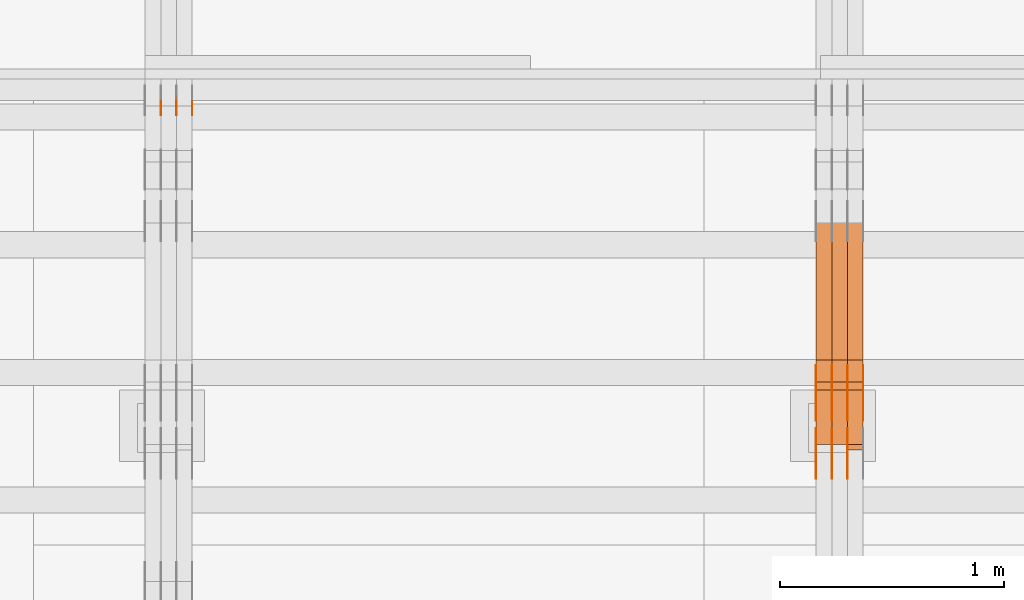
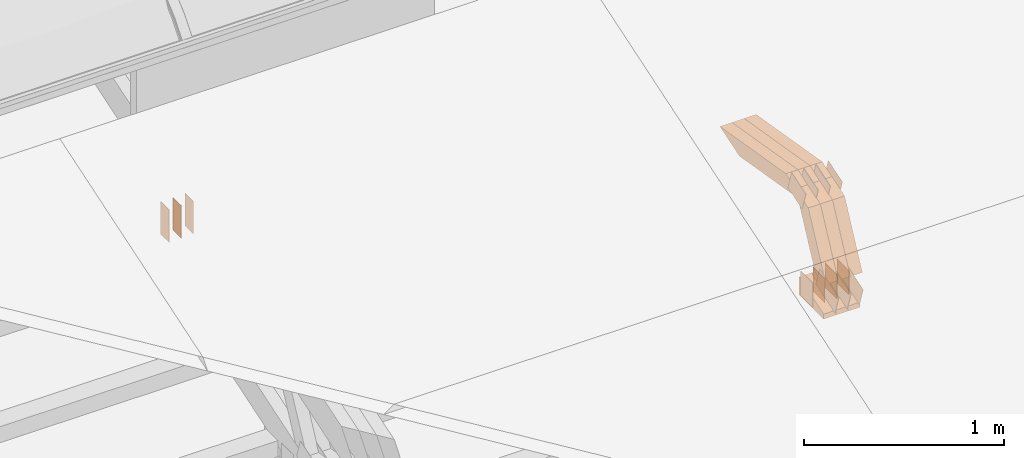
# One storey, part 282 of 385: 30 proxies.
"""IFC2X3 building model written with IfcOpenShell, lengths in millimetres."""

from ifc_helpers import new_model, entity, si_unit, converted_unit, derived_unit, direction, frame, frame_2d, origin, place, context, subcontext, project, spatial, polyline, rectangle, outline, extrude, source, transform, mapped, material, type_object, type_shapes, element, save


model = new_model("IFC2X3")

# Units and contexts
model_context = context("Model", 3, precision=0.01, world=origin(), true_north=direction((6.12303176911189e-17, 1.0)))
body_context = subcontext(model_context, "Body", "Model", "MODEL_VIEW")
ifc_project = project(units=[si_unit("LENGTHUNIT", "METRE", prefix="MILLI"), si_unit("AREAUNIT", "SQUARE_METRE"), si_unit("VOLUMEUNIT", "CUBIC_METRE"), converted_unit("PLANEANGLEUNIT", "DEGREE", entity("IfcRatioMeasure", 0.0174532925199433), si_unit("PLANEANGLEUNIT", "RADIAN"), dimensions=[0, 0, 0, 0, 0, 0, 0]), si_unit("MASSUNIT", "GRAM", prefix="KILO"), derived_unit("MASSDENSITYUNIT", [(si_unit("MASSUNIT", "GRAM", prefix="KILO"), 1), (si_unit("LENGTHUNIT", "METRE"), -3)]), si_unit("TIMEUNIT", "SECOND"), si_unit("FREQUENCYUNIT", "HERTZ"), si_unit("THERMODYNAMICTEMPERATUREUNIT", "DEGREE_CELSIUS"), derived_unit("THERMALTRANSMITTANCEUNIT", [(si_unit("MASSUNIT", "GRAM", prefix="KILO"), 1), (si_unit("THERMODYNAMICTEMPERATUREUNIT", "KELVIN"), -1), (si_unit("TIMEUNIT", "SECOND"), -3)]), derived_unit("VOLUMETRICFLOWRATEUNIT", [(si_unit("LENGTHUNIT", "METRE"), 3), (si_unit("TIMEUNIT", "SECOND"), -1)]), si_unit("ELECTRICCURRENTUNIT", "AMPERE"), si_unit("ELECTRICVOLTAGEUNIT", "VOLT"), si_unit("POWERUNIT", "WATT"), si_unit("FORCEUNIT", "NEWTON", prefix="KILO"), si_unit("ILLUMINANCEUNIT", "LUX"), si_unit("LUMINOUSFLUXUNIT", "LUMEN"), si_unit("LUMINOUSINTENSITYUNIT", "CANDELA"), derived_unit("USERDEFINED", [(si_unit("MASSUNIT", "GRAM", prefix="KILO"), -1), (si_unit("LENGTHUNIT", "METRE"), -2), (si_unit("TIMEUNIT", "SECOND"), 3), (si_unit("LUMINOUSFLUXUNIT", "LUMEN"), 1)]), derived_unit("LINEARVELOCITYUNIT", [(si_unit("LENGTHUNIT", "METRE"), 1), (si_unit("TIMEUNIT", "SECOND"), -1)]), si_unit("PRESSUREUNIT", "PASCAL"), derived_unit("USERDEFINED", [(si_unit("LENGTHUNIT", "METRE"), -2), (si_unit("MASSUNIT", "GRAM", prefix="KILO"), 1), (si_unit("TIMEUNIT", "SECOND"), -2)])], contexts=[model_context])

# Site, building, storey
site_placement = place(None, origin())
site = spatial("IfcSite", under=ifc_project, at=site_placement, CompositionType="ELEMENT")
building_placement = place(site_placement, origin())
building = spatial("IfcBuilding", under=site, at=building_placement, CompositionType="ELEMENT")
storey_placement = place(building_placement, origin())
storey = spatial("IfcBuildingStorey", under=building, at=storey_placement, Name="Default", CompositionType="ELEMENT", Elevation=0.0)

# Proxies
ifc_material_1 = material(Name="IfcSurfaceStyle #482430")
building_element_proxy_type_1 = type_object("IfcBuildingElementProxyType", PredefinedType="NOTDEFINED", material=ifc_material_1)
shared_shape_1 = source(origin(), body_context, "Body", "SweptSolid", [
    extrude(outline(polyline([(-99.9997874178038, -60.0000528641967), (99.9998102700997, -60.0000528641967), (99.9998251396068, 60.0000528641967), (-99.9998479919027, 60.0000528641967), (-99.9997874178038, -60.0000528641967)])), frame((99.9999918898597, 60.0000528641967, 0.0), z_axis=(0.0, 0.0, 1.0), x_axis=(-1.0, 0.0, 0.0)), (0.0, 0.0, 1.0), 1.3),
])
type_shapes(building_element_proxy_type_1, [shared_shape_1])
proxy_1_placement = place(building_placement, frame((39316.3, 11991.9568177725, 3072.52282247925), z_axis=(-1.0, 0.0, 0.0), x_axis=(0.0, 0.951056516295124, 0.309016994375039)))
element("IfcBuildingElementProxy", 1, at=proxy_1_placement, inside=storey, type_object=building_element_proxy_type_1, material=ifc_material_1, context=body_context, shape_type="MappedRepresentation", body=[
    mapped(shared_shape_1, transform((0.0, 0.0, 0.0), scale=1.0)),
])
ifc_material_2 = material(Name="IfcSurfaceStyle #482373")
building_element_proxy_type_2 = type_object("IfcBuildingElementProxyType", PredefinedType="NOTDEFINED", material=ifc_material_2)
shared_shape_2 = source(origin(), body_context, "Body", "SweptSolid", [
    extrude(outline(polyline([(-99.9997874178038, -60.0000528641967), (99.9998102700997, -60.0000528641967), (99.9998251396068, 60.0000528641967), (-99.9998479919027, 60.0000528641967), (-99.9997874178038, -60.0000528641967)])), frame((99.9999918898597, 60.0000528641967, 0.0), z_axis=(0.0, 0.0, 1.0), x_axis=(-1.0, 0.0, 0.0)), (0.0, 0.0, 1.0), 1.29999999999998),
])
type_shapes(building_element_proxy_type_2, [shared_shape_2])
proxy_2_placement = place(building_placement, frame((39245.0, 11991.9568177725, 3072.52282247925), z_axis=(-1.0, 0.0, 0.0), x_axis=(0.0, 0.951056516295124, 0.309016994375039)))
element("IfcBuildingElementProxy", 2, at=proxy_2_placement, inside=storey, type_object=building_element_proxy_type_2, material=ifc_material_2, context=body_context, shape_type="MappedRepresentation", body=[
    mapped(shared_shape_2, transform((0.0, 0.0, 0.0), scale=1.0)),
])
ifc_material_3 = material(Name="IfcSurfaceStyle #482316")
building_element_proxy_type_3 = type_object("IfcBuildingElementProxyType", PredefinedType="NOTDEFINED", material=ifc_material_3)
shared_shape_3 = source(origin(), body_context, "Body", "SweptSolid", [
    extrude(outline(polyline([(-99.9997874178038, -60.0000528641967), (99.9998102700997, -60.0000528641967), (99.9998251396068, 60.0000528641967), (-99.9998479919027, 60.0000528641967), (-99.9997874178038, -60.0000528641967)])), frame((99.9999918898597, 60.0000528641967, 0.0), z_axis=(0.0, 0.0, 1.0), x_axis=(-1.0, 0.0, 0.0)), (0.0, 0.0, 1.0), 1.29999999999998),
])
type_shapes(building_element_proxy_type_3, [shared_shape_3])
proxy_3_placement = place(building_placement, frame((39246.3, 11991.9568177725, 3072.52282247925), z_axis=(-1.0, 0.0, 0.0), x_axis=(0.0, 0.951056516295124, 0.309016994375039)))
element("IfcBuildingElementProxy", 3, at=proxy_3_placement, inside=storey, type_object=building_element_proxy_type_3, material=ifc_material_3, context=body_context, shape_type="MappedRepresentation", body=[
    mapped(shared_shape_3, transform((0.0, 0.0, 0.0), scale=1.0)),
])
ifc_material_4 = material(Name="IfcSurfaceStyle #482259")
building_element_proxy_type_4 = type_object("IfcBuildingElementProxyType", PredefinedType="NOTDEFINED", material=ifc_material_4)
shared_shape_4 = source(origin(), body_context, "Body", "SweptSolid", [
    extrude(outline(polyline([(-99.9997874178038, -60.0000528641967), (99.9998102700997, -60.0000528641967), (99.9998251396068, 60.0000528641967), (-99.9998479919027, 60.0000528641967), (-99.9997874178038, -60.0000528641967)])), frame((99.9999918898597, 60.0000528641967, 0.0), z_axis=(0.0, 0.0, 1.0), x_axis=(-1.0, 0.0, 0.0)), (0.0, 0.0, 1.0), 1.29999999999999),
])
type_shapes(building_element_proxy_type_4, [shared_shape_4])
proxy_4_placement = place(building_placement, frame((39175.0, 11991.9568177725, 3072.52282247925), z_axis=(-1.0, 0.0, 0.0), x_axis=(0.0, 0.951056516295124, 0.309016994375039)))
element("IfcBuildingElementProxy", 4, at=proxy_4_placement, inside=storey, type_object=building_element_proxy_type_4, material=ifc_material_4, context=body_context, shape_type="MappedRepresentation", body=[
    mapped(shared_shape_4, transform((0.0, 0.0, 0.0), scale=1.0)),
])
ifc_material_5 = material(Name="IfcSurfaceStyle #482202")
building_element_proxy_type_5 = type_object("IfcBuildingElementProxyType", PredefinedType="NOTDEFINED", material=ifc_material_5)
shared_shape_5 = source(origin(), body_context, "Body", "SweptSolid", [
    extrude(rectangle(XDim=150.0, YDim=119.999999999985, at=frame_2d((-7.105427357601e-15, 0.0), x_axis=(1.0, 0.0))), frame((75.0, 60.0, 0.0), z_axis=(0.0, 0.0, 1.0), x_axis=(-1.0, 0.0, 0.0)), (0.0, 0.0, 1.0), 1.3),
])
type_shapes(building_element_proxy_type_5, [shared_shape_5])
proxy_5_placement = place(building_placement, frame((39386.3, 12372.95703125, 3007.04687500001), z_axis=(-1.0, 0.0, 0.0), x_axis=(0.0, 0.0, -1.0)))
element("IfcBuildingElementProxy", 5, at=proxy_5_placement, inside=storey, type_object=building_element_proxy_type_5, material=ifc_material_5, context=body_context, shape_type="MappedRepresentation", body=[
    mapped(shared_shape_5, transform((0.0, 0.0, 0.0), scale=1.0)),
])
ifc_material_6 = material(Name="IfcSurfaceStyle #482145")
building_element_proxy_type_6 = type_object("IfcBuildingElementProxyType", PredefinedType="NOTDEFINED", material=ifc_material_6)
shared_shape_6 = source(origin(), body_context, "Body", "SweptSolid", [
    extrude(rectangle(XDim=150.0, YDim=119.999999999985, at=frame_2d((-7.105427357601e-15, 0.0), x_axis=(1.0, 0.0))), frame((75.0, 60.0, 0.0), z_axis=(0.0, 0.0, 1.0), x_axis=(-1.0, 0.0, 0.0)), (0.0, 0.0, 1.0), 1.3),
])
type_shapes(building_element_proxy_type_6, [shared_shape_6])
proxy_6_placement = place(building_placement, frame((39315.0, 12372.95703125, 3007.04687500001), z_axis=(-1.0, 0.0, 0.0), x_axis=(0.0, 0.0, -1.0)))
element("IfcBuildingElementProxy", 6, at=proxy_6_placement, inside=storey, type_object=building_element_proxy_type_6, material=ifc_material_6, context=body_context, shape_type="MappedRepresentation", body=[
    mapped(shared_shape_6, transform((0.0, 0.0, 0.0), scale=1.0)),
])
ifc_material_7 = material(Name="IfcSurfaceStyle #482088")
building_element_proxy_type_7 = type_object("IfcBuildingElementProxyType", PredefinedType="NOTDEFINED", material=ifc_material_7)
shared_shape_7 = source(origin(), body_context, "Body", "SweptSolid", [
    extrude(rectangle(XDim=150.0, YDim=119.999999999985, at=frame_2d((-7.105427357601e-15, 0.0), x_axis=(1.0, 0.0))), frame((75.0, 60.0, 0.0), z_axis=(0.0, 0.0, 1.0), x_axis=(-1.0, 0.0, 0.0)), (0.0, 0.0, 1.0), 1.3),
])
type_shapes(building_element_proxy_type_7, [shared_shape_7])
proxy_7_placement = place(building_placement, frame((39316.3, 12372.95703125, 3007.04687500001), z_axis=(-1.0, 0.0, 0.0), x_axis=(0.0, 0.0, -1.0)))
element("IfcBuildingElementProxy", 7, at=proxy_7_placement, inside=storey, type_object=building_element_proxy_type_7, material=ifc_material_7, context=body_context, shape_type="MappedRepresentation", body=[
    mapped(shared_shape_7, transform((0.0, 0.0, 0.0), scale=1.0)),
])
ifc_material_8 = material(Name="IfcSurfaceStyle #482031")
building_element_proxy_type_8 = type_object("IfcBuildingElementProxyType", PredefinedType="NOTDEFINED", material=ifc_material_8)
shared_shape_8 = source(origin(), body_context, "Body", "SweptSolid", [
    extrude(rectangle(XDim=150.0, YDim=119.999999999985, at=frame_2d((-7.105427357601e-15, 0.0), x_axis=(1.0, 0.0))), frame((75.0, 60.0, 0.0), z_axis=(0.0, 0.0, 1.0), x_axis=(-1.0, 0.0, 0.0)), (0.0, 0.0, 1.0), 1.29999999999999),
])
type_shapes(building_element_proxy_type_8, [shared_shape_8])
proxy_8_placement = place(building_placement, frame((39245.0, 12372.95703125, 3007.04687500001), z_axis=(-1.0, 0.0, 0.0), x_axis=(0.0, 0.0, -1.0)))
element("IfcBuildingElementProxy", 8, at=proxy_8_placement, inside=storey, type_object=building_element_proxy_type_8, material=ifc_material_8, context=body_context, shape_type="MappedRepresentation", body=[
    mapped(shared_shape_8, transform((0.0, 0.0, 0.0), scale=1.0)),
])
ifc_material_9 = material(Name="IfcSurfaceStyle #481974")
building_element_proxy_type_9 = type_object("IfcBuildingElementProxyType", PredefinedType="NOTDEFINED", material=ifc_material_9)
shared_shape_9 = source(origin(), body_context, "Body", "SweptSolid", [
    extrude(rectangle(XDim=150.0, YDim=119.999999999985, at=frame_2d((-7.105427357601e-15, 0.0), x_axis=(1.0, 0.0))), frame((75.0, 60.0, 0.0), z_axis=(0.0, 0.0, 1.0), x_axis=(-1.0, 0.0, 0.0)), (0.0, 0.0, 1.0), 1.29999999999999),
])
type_shapes(building_element_proxy_type_9, [shared_shape_9])
proxy_9_placement = place(building_placement, frame((39246.3, 12372.95703125, 3007.04687500001), z_axis=(-1.0, 0.0, 0.0), x_axis=(0.0, 0.0, -1.0)))
element("IfcBuildingElementProxy", 9, at=proxy_9_placement, inside=storey, type_object=building_element_proxy_type_9, material=ifc_material_9, context=body_context, shape_type="MappedRepresentation", body=[
    mapped(shared_shape_9, transform((0.0, 0.0, 0.0), scale=1.0)),
])
ifc_material_10 = material(Name="IfcSurfaceStyle #481917")
building_element_proxy_type_10 = type_object("IfcBuildingElementProxyType", PredefinedType="NOTDEFINED", material=ifc_material_10)
shared_shape_10 = source(origin(), body_context, "Body", "SweptSolid", [
    extrude(rectangle(XDim=150.0, YDim=119.999999999985, at=frame_2d((-7.105427357601e-15, 0.0), x_axis=(1.0, 0.0))), frame((75.0, 60.0, 0.0), z_axis=(0.0, 0.0, 1.0), x_axis=(-1.0, 0.0, 0.0)), (0.0, 0.0, 1.0), 1.29999999999999),
])
type_shapes(building_element_proxy_type_10, [shared_shape_10])
proxy_10_placement = place(building_placement, frame((39175.0, 12372.95703125, 3007.04687500001), z_axis=(-1.0, 0.0, 0.0), x_axis=(0.0, 0.0, -1.0)))
element("IfcBuildingElementProxy", 10, at=proxy_10_placement, inside=storey, type_object=building_element_proxy_type_10, material=ifc_material_10, context=body_context, shape_type="MappedRepresentation", body=[
    mapped(shared_shape_10, transform((0.0, 0.0, 0.0), scale=1.0)),
])
ifc_material_11 = material(Name="IfcSurfaceStyle #475020")
building_element_proxy_type_11 = type_object("IfcBuildingElementProxyType", PredefinedType="NOTDEFINED", material=ifc_material_11)
shared_shape_11 = source(origin(), body_context, "Body", "SweptSolid", [
    extrude(outline(polyline([(-74.9998754286244, -60.0000016373506), (74.9998605591063, -60.0000016373506), (74.9998754286244, 60.0000016373506), (-74.9998605591063, 60.0000016373506), (-74.9998754286244, -60.0000016373506)])), frame((74.9998754286244, 60.0000016373506, 0.0), z_axis=(0.0, 0.0, 1.0), x_axis=(-1.0, 0.0, 0.0)), (0.0, 0.0, 1.0), 1.3),
])
type_shapes(building_element_proxy_type_11, [shared_shape_11])
proxy_11_placement = place(building_placement, frame((39386.3, 12321.1620861463, 3506.17707344366), z_axis=(-1.0, 0.0, 0.0), x_axis=(0.0, 0.951056516295154, 0.309016994374948)))
element("IfcBuildingElementProxy", 11, at=proxy_11_placement, inside=storey, type_object=building_element_proxy_type_11, material=ifc_material_11, context=body_context, shape_type="MappedRepresentation", body=[
    mapped(shared_shape_11, transform((0.0, 0.0, 0.0), scale=1.0)),
])
ifc_material_12 = material(Name="IfcSurfaceStyle #474963")
building_element_proxy_type_12 = type_object("IfcBuildingElementProxyType", PredefinedType="NOTDEFINED", material=ifc_material_12)
shared_shape_12 = source(origin(), body_context, "Body", "SweptSolid", [
    extrude(outline(polyline([(-74.9998754286244, -60.0000016373506), (74.9998605591063, -60.0000016373506), (74.9998754286244, 60.0000016373506), (-74.9998605591063, 60.0000016373506), (-74.9998754286244, -60.0000016373506)])), frame((74.9998754286244, 60.0000016373506, 0.0), z_axis=(0.0, 0.0, 1.0), x_axis=(-1.0, 0.0, 0.0)), (0.0, 0.0, 1.0), 1.3),
])
type_shapes(building_element_proxy_type_12, [shared_shape_12])
proxy_12_placement = place(building_placement, frame((39315.0, 12321.1620861463, 3506.17707344366), z_axis=(-1.0, 0.0, 0.0), x_axis=(0.0, 0.951056516295154, 0.309016994374948)))
element("IfcBuildingElementProxy", 12, at=proxy_12_placement, inside=storey, type_object=building_element_proxy_type_12, material=ifc_material_12, context=body_context, shape_type="MappedRepresentation", body=[
    mapped(shared_shape_12, transform((0.0, 0.0, 0.0), scale=1.0)),
])
ifc_material_13 = material(Name="IfcSurfaceStyle #474906")
building_element_proxy_type_13 = type_object("IfcBuildingElementProxyType", PredefinedType="NOTDEFINED", material=ifc_material_13)
shared_shape_13 = source(origin(), body_context, "Body", "SweptSolid", [
    extrude(outline(polyline([(-74.9998754286244, -60.0000016373506), (74.9998605591063, -60.0000016373506), (74.9998754286244, 60.0000016373506), (-74.9998605591063, 60.0000016373506), (-74.9998754286244, -60.0000016373506)])), frame((74.9998754286244, 60.0000016373506, 0.0), z_axis=(0.0, 0.0, 1.0), x_axis=(-1.0, 0.0, 0.0)), (0.0, 0.0, 1.0), 1.3),
])
type_shapes(building_element_proxy_type_13, [shared_shape_13])
proxy_13_placement = place(building_placement, frame((39316.3, 12321.1620861463, 3506.17707344366), z_axis=(-1.0, 0.0, 0.0), x_axis=(0.0, 0.951056516295154, 0.309016994374948)))
element("IfcBuildingElementProxy", 13, at=proxy_13_placement, inside=storey, type_object=building_element_proxy_type_13, material=ifc_material_13, context=body_context, shape_type="MappedRepresentation", body=[
    mapped(shared_shape_13, transform((0.0, 0.0, 0.0), scale=1.0)),
])
ifc_material_14 = material(Name="IfcSurfaceStyle #474849")
building_element_proxy_type_14 = type_object("IfcBuildingElementProxyType", PredefinedType="NOTDEFINED", material=ifc_material_14)
shared_shape_14 = source(origin(), body_context, "Body", "SweptSolid", [
    extrude(outline(polyline([(-74.9998754286244, -60.0000016373506), (74.9998605591063, -60.0000016373506), (74.9998754286244, 60.0000016373506), (-74.9998605591063, 60.0000016373506), (-74.9998754286244, -60.0000016373506)])), frame((74.9998754286244, 60.0000016373506, 0.0), z_axis=(0.0, 0.0, 1.0), x_axis=(-1.0, 0.0, 0.0)), (0.0, 0.0, 1.0), 1.29999999999999),
])
type_shapes(building_element_proxy_type_14, [shared_shape_14])
proxy_14_placement = place(building_placement, frame((39245.0, 12321.1620861463, 3506.17707344366), z_axis=(-1.0, 0.0, 0.0), x_axis=(0.0, 0.951056516295154, 0.309016994374948)))
element("IfcBuildingElementProxy", 14, at=proxy_14_placement, inside=storey, type_object=building_element_proxy_type_14, material=ifc_material_14, context=body_context, shape_type="MappedRepresentation", body=[
    mapped(shared_shape_14, transform((0.0, 0.0, 0.0), scale=1.0)),
])
ifc_material_15 = material(Name="IfcSurfaceStyle #474792")
building_element_proxy_type_15 = type_object("IfcBuildingElementProxyType", PredefinedType="NOTDEFINED", material=ifc_material_15)
shared_shape_15 = source(origin(), body_context, "Body", "SweptSolid", [
    extrude(outline(polyline([(-74.9998754286244, -60.0000016373506), (74.9998605591063, -60.0000016373506), (74.9998754286244, 60.0000016373506), (-74.9998605591063, 60.0000016373506), (-74.9998754286244, -60.0000016373506)])), frame((74.9998754286244, 60.0000016373506, 0.0), z_axis=(0.0, 0.0, 1.0), x_axis=(-1.0, 0.0, 0.0)), (0.0, 0.0, 1.0), 1.29999999999999),
])
type_shapes(building_element_proxy_type_15, [shared_shape_15])
proxy_15_placement = place(building_placement, frame((39246.3, 12321.1620861463, 3506.17707344366), z_axis=(-1.0, 0.0, 0.0), x_axis=(0.0, 0.951056516295154, 0.309016994374948)))
element("IfcBuildingElementProxy", 15, at=proxy_15_placement, inside=storey, type_object=building_element_proxy_type_15, material=ifc_material_15, context=body_context, shape_type="MappedRepresentation", body=[
    mapped(shared_shape_15, transform((0.0, 0.0, 0.0), scale=1.0)),
])
ifc_material_16 = material(Name="IfcSurfaceStyle #474735")
building_element_proxy_type_16 = type_object("IfcBuildingElementProxyType", PredefinedType="NOTDEFINED", material=ifc_material_16)
shared_shape_16 = source(origin(), body_context, "Body", "SweptSolid", [
    extrude(outline(polyline([(-74.9998754286244, -60.0000016373506), (74.9998605591063, -60.0000016373506), (74.9998754286244, 60.0000016373506), (-74.9998605591063, 60.0000016373506), (-74.9998754286244, -60.0000016373506)])), frame((74.9998754286244, 60.0000016373506, 0.0), z_axis=(0.0, 0.0, 1.0), x_axis=(-1.0, 0.0, 0.0)), (0.0, 0.0, 1.0), 1.29999999999999),
])
type_shapes(building_element_proxy_type_16, [shared_shape_16])
proxy_16_placement = place(building_placement, frame((39175.0, 12321.1620861463, 3506.17707344366), z_axis=(-1.0, 0.0, 0.0), x_axis=(0.0, 0.951056516295154, 0.309016994374948)))
element("IfcBuildingElementProxy", 16, at=proxy_16_placement, inside=storey, type_object=building_element_proxy_type_16, material=ifc_material_16, context=body_context, shape_type="MappedRepresentation", body=[
    mapped(shared_shape_16, transform((0.0, 0.0, 0.0), scale=1.0)),
])
ifc_material_17 = material(Name="IfcSurfaceStyle #466560")
building_element_proxy_type_17 = type_object("IfcBuildingElementProxyType", Name="T1-E1 466558", PredefinedType="NOTDEFINED", material=ifc_material_17)
shared_shape_17 = source(origin(), body_context, "Body", "SweptSolid", [
    extrude(outline(polyline([(-75.1378173828004, -122.500000000005), (35.3350830078246, -122.500000000005), (35.3350830078004, 122.500000000005), (4.46765136717545, 122.500000000005), (-75.1378173828004, -122.500000000005)])), frame((35.3350830078246, 122.500000104877, 0.0), z_axis=(0.0, 0.0, 1.0), x_axis=(-1.0, 0.0, 0.0)), (0.0, 0.0, 1.0), 70.0),
])
type_shapes(building_element_proxy_type_17, [shared_shape_17])
proxy_17_placement = place(building_placement, frame((39385.0, 12145.0, 2849.54565429685), z_axis=(-1.0, 0.0, 0.0), x_axis=(0.0, 0.0, 1.0)))
element("IfcBuildingElementProxy", 17, at=proxy_17_placement, inside=storey, type_object=building_element_proxy_type_17, material=ifc_material_17, Name="T1-E1", context=body_context, shape_type="MappedRepresentation", body=[
    mapped(shared_shape_17, transform((0.0, 0.0, 0.0), scale=1.0)),
])
ifc_material_18 = material(Name="IfcSurfaceStyle #466503")
building_element_proxy_type_18 = type_object("IfcBuildingElementProxyType", Name="T1-E1 466501", PredefinedType="NOTDEFINED", material=ifc_material_18)
shared_shape_18 = source(origin(), body_context, "Body", "SweptSolid", [
    extrude(outline(polyline([(-75.1378173828004, -122.500000000005), (35.3350830078246, -122.500000000005), (35.3350830078004, 122.500000000005), (4.46765136717545, 122.500000000005), (-75.1378173828004, -122.500000000005)])), frame((35.3350830078246, 122.500000104877, 0.0), z_axis=(0.0, 0.0, 1.0), x_axis=(-1.0, 0.0, 0.0)), (0.0, 0.0, 1.0), 70.0),
])
type_shapes(building_element_proxy_type_18, [shared_shape_18])
proxy_18_placement = place(building_placement, frame((39315.0, 12145.0, 2849.54565429685), z_axis=(-1.0, 0.0, 0.0), x_axis=(0.0, 0.0, 1.0)))
element("IfcBuildingElementProxy", 18, at=proxy_18_placement, inside=storey, type_object=building_element_proxy_type_18, material=ifc_material_18, Name="T1-E1", context=body_context, shape_type="MappedRepresentation", body=[
    mapped(shared_shape_18, transform((0.0, 0.0, 0.0), scale=1.0)),
])
ifc_material_19 = material(Name="IfcSurfaceStyle #466446")
building_element_proxy_type_19 = type_object("IfcBuildingElementProxyType", Name="T1-E1 466444", PredefinedType="NOTDEFINED", material=ifc_material_19)
shared_shape_19 = source(origin(), body_context, "Body", "SweptSolid", [
    extrude(outline(polyline([(-75.1378173828004, -122.500000000005), (35.3350830078246, -122.500000000005), (35.3350830078004, 122.500000000005), (4.46765136717545, 122.500000000005), (-75.1378173828004, -122.500000000005)])), frame((35.3350830078246, 122.500000104877, 0.0), z_axis=(0.0, 0.0, 1.0), x_axis=(-1.0, 0.0, 0.0)), (0.0, 0.0, 1.0), 70.0),
])
type_shapes(building_element_proxy_type_19, [shared_shape_19])
proxy_19_placement = place(building_placement, frame((39245.0, 12145.0, 2849.54565429685), z_axis=(-1.0, 0.0, 0.0), x_axis=(0.0, 0.0, 1.0)))
element("IfcBuildingElementProxy", 19, at=proxy_19_placement, inside=storey, type_object=building_element_proxy_type_19, material=ifc_material_19, Name="T1-E1", context=body_context, shape_type="MappedRepresentation", body=[
    mapped(shared_shape_19, transform((0.0, 0.0, 0.0), scale=1.0)),
])
ifc_material_20 = material(Name="IfcSurfaceStyle #464832")
building_element_proxy_type_20 = type_object("IfcBuildingElementProxyType", Name="T1-W7 464830", PredefinedType="NOTDEFINED", material=ifc_material_20)
shared_shape_20 = source(origin(), body_context, "Body", "SweptSolid", [
    extrude(outline(polyline([(-296.174043820986, -47.5000676566704), (297.841254477443, -47.5000676566704), (283.518570346415, -7.10254316533821e-06), (192.674144473719, 47.500071207942), (-477.859925476591, 47.500071207942), (-296.174043820986, -47.5000676566704)])), frame((297.841254477443, 47.5000816097442, 0.0), z_axis=(0.0, 0.0, 1.0), x_axis=(-1.0, 0.0, 0.0)), (0.0, 0.0, 1.0), 70.0),
])
type_shapes(building_element_proxy_type_20, [shared_shape_20])
proxy_20_placement = place(building_placement, frame((39385.0, 12419.2991208897, 3526.2136755972), z_axis=(-1.0, 0.0, 0.0), x_axis=(0.0, 0.985983815111804, -0.166840991178939)))
element("IfcBuildingElementProxy", 20, at=proxy_20_placement, inside=storey, type_object=building_element_proxy_type_20, material=ifc_material_20, Name="T1-W7", context=body_context, shape_type="MappedRepresentation", body=[
    mapped(shared_shape_20, transform((0.0, 0.0, 0.0), scale=1.0)),
])
ifc_material_21 = material(Name="IfcSurfaceStyle #464766")
building_element_proxy_type_21 = type_object("IfcBuildingElementProxyType", Name="T1-W7 464764", PredefinedType="NOTDEFINED", material=ifc_material_21)
shared_shape_21 = source(origin(), body_context, "Body", "SweptSolid", [
    extrude(outline(polyline([(-296.174043820986, -47.5000676566704), (297.841254477443, -47.5000676566704), (283.518570346415, -7.10254316533821e-06), (192.674144473719, 47.500071207942), (-477.859925476591, 47.500071207942), (-296.174043820986, -47.5000676566704)])), frame((297.841254477443, 47.5000816097442, 0.0), z_axis=(0.0, 0.0, 1.0), x_axis=(-1.0, 0.0, 0.0)), (0.0, 0.0, 1.0), 70.0),
])
type_shapes(building_element_proxy_type_21, [shared_shape_21])
proxy_21_placement = place(building_placement, frame((39315.0, 12419.2991208897, 3526.2136755972), z_axis=(-1.0, 0.0, 0.0), x_axis=(0.0, 0.985983815111804, -0.166840991178939)))
element("IfcBuildingElementProxy", 21, at=proxy_21_placement, inside=storey, type_object=building_element_proxy_type_21, material=ifc_material_21, Name="T1-W7", context=body_context, shape_type="MappedRepresentation", body=[
    mapped(shared_shape_21, transform((0.0, 0.0, 0.0), scale=1.0)),
])
ifc_material_22 = material(Name="IfcSurfaceStyle #464700")
building_element_proxy_type_22 = type_object("IfcBuildingElementProxyType", Name="T1-W7 464698", PredefinedType="NOTDEFINED", material=ifc_material_22)
shared_shape_22 = source(origin(), body_context, "Body", "SweptSolid", [
    extrude(outline(polyline([(-296.174043820986, -47.5000676566704), (297.841254477443, -47.5000676566704), (283.518570346415, -7.10254316533821e-06), (192.674144473719, 47.500071207942), (-477.859925476591, 47.500071207942), (-296.174043820986, -47.5000676566704)])), frame((297.841254477443, 47.5000816097442, 0.0), z_axis=(0.0, 0.0, 1.0), x_axis=(-1.0, 0.0, 0.0)), (0.0, 0.0, 1.0), 70.0),
])
type_shapes(building_element_proxy_type_22, [shared_shape_22])
proxy_22_placement = place(building_placement, frame((39245.0, 12419.2991208897, 3526.2136755972), z_axis=(-1.0, 0.0, 0.0), x_axis=(0.0, 0.985983815111804, -0.166840991178939)))
element("IfcBuildingElementProxy", 22, at=proxy_22_placement, inside=storey, type_object=building_element_proxy_type_22, material=ifc_material_22, Name="T1-W7", context=body_context, shape_type="MappedRepresentation", body=[
    mapped(shared_shape_22, transform((0.0, 0.0, 0.0), scale=1.0)),
])
ifc_material_23 = material(Name="IfcSurfaceStyle #464436")
building_element_proxy_type_23 = type_object("IfcBuildingElementProxyType", Name="T1-W36 464434", PredefinedType="NOTDEFINED", material=ifc_material_23)
shared_shape_23 = source(origin(), body_context, "Body", "SweptSolid", [
    extrude(outline(polyline([(-300.714670922549, -47.4998881108849), (134.031527004269, -47.499888110885), (180.52054953879, -0.000136170977331764), (193.89900152221, 47.500563476126), (-207.736407142719, 47.4993489166213), (-300.714670922549, -47.4998881108849)])), frame((193.899145164686, 47.5001861375837, 0.0), z_axis=(0.0, 0.0, 1.0), x_axis=(-1.0, 3.02403492980632e-06, 0.0)), (0.0, 0.0, 1.0), 70.0),
])
type_shapes(building_element_proxy_type_23, [shared_shape_23])
proxy_23_placement = place(building_placement, frame((39385.0, 12120.5935627532, 3076.1128858536), z_axis=(-1.0, 0.0, 0.0), x_axis=(0.0, 0.444384650266842, 0.895836080210669)))
element("IfcBuildingElementProxy", 23, at=proxy_23_placement, inside=storey, type_object=building_element_proxy_type_23, material=ifc_material_23, Name="T1-W36", context=body_context, shape_type="MappedRepresentation", body=[
    mapped(shared_shape_23, transform((0.0, 0.0, 0.0), scale=1.0)),
])
ifc_material_24 = material(Name="IfcSurfaceStyle #464370")
building_element_proxy_type_24 = type_object("IfcBuildingElementProxyType", Name="T1-W36 464368", PredefinedType="NOTDEFINED", material=ifc_material_24)
shared_shape_24 = source(origin(), body_context, "Body", "SweptSolid", [
    extrude(outline(polyline([(-300.714670922549, -47.4998881108849), (134.031527004269, -47.499888110885), (180.52054953879, -0.000136170977331764), (193.89900152221, 47.500563476126), (-207.736407142719, 47.4993489166213), (-300.714670922549, -47.4998881108849)])), frame((193.899145164686, 47.5001861375837, 0.0), z_axis=(0.0, 0.0, 1.0), x_axis=(-1.0, 3.02403492980632e-06, 0.0)), (0.0, 0.0, 1.0), 70.0),
])
type_shapes(building_element_proxy_type_24, [shared_shape_24])
proxy_24_placement = place(building_placement, frame((39315.0, 12120.5935627532, 3076.1128858536), z_axis=(-1.0, 0.0, 0.0), x_axis=(0.0, 0.444384650266842, 0.895836080210669)))
element("IfcBuildingElementProxy", 24, at=proxy_24_placement, inside=storey, type_object=building_element_proxy_type_24, material=ifc_material_24, Name="T1-W36", context=body_context, shape_type="MappedRepresentation", body=[
    mapped(shared_shape_24, transform((0.0, 0.0, 0.0), scale=1.0)),
])
ifc_material_25 = material(Name="IfcSurfaceStyle #464304")
building_element_proxy_type_25 = type_object("IfcBuildingElementProxyType", Name="T1-W36 464302", PredefinedType="NOTDEFINED", material=ifc_material_25)
shared_shape_25 = source(origin(), body_context, "Body", "SweptSolid", [
    extrude(outline(polyline([(-300.714670922549, -47.4998881108849), (134.031527004269, -47.499888110885), (180.52054953879, -0.000136170977331764), (193.89900152221, 47.500563476126), (-207.736407142719, 47.4993489166213), (-300.714670922549, -47.4998881108849)])), frame((193.899145164686, 47.5001861375837, 0.0), z_axis=(0.0, 0.0, 1.0), x_axis=(-1.0, 3.02403492980632e-06, 0.0)), (0.0, 0.0, 1.0), 70.0),
])
type_shapes(building_element_proxy_type_25, [shared_shape_25])
proxy_25_placement = place(building_placement, frame((39245.0, 12120.5935627532, 3076.1128858536), z_axis=(-1.0, 0.0, 0.0), x_axis=(0.0, 0.444384650266842, 0.895836080210669)))
element("IfcBuildingElementProxy", 25, at=proxy_25_placement, inside=storey, type_object=building_element_proxy_type_25, material=ifc_material_25, Name="T1-W36", context=body_context, shape_type="MappedRepresentation", body=[
    mapped(shared_shape_25, transform((0.0, 0.0, 0.0), scale=1.0)),
])
ifc_material_26 = material(Name="IfcSurfaceStyle #450164")
building_element_proxy_type_26 = type_object("IfcBuildingElementProxyType", PredefinedType="NOTDEFINED", material=ifc_material_26)
shared_shape_26 = source(origin(), body_context, "Body", "SweptSolid", [
    extrude(rectangle(XDim=200.0, YDim=84.0, at=frame_2d((0.0, -7.105427357601e-15), x_axis=(1.0, 0.0))), frame((100.0, 42.0, 0.0), z_axis=(0.0, 0.0, 1.0), x_axis=(-1.0, 0.0, 0.0)), (0.0, 0.0, 1.0), 1.3),
])
type_shapes(building_element_proxy_type_26, [shared_shape_26])
proxy_26_placement = place(building_placement, frame((36386.3, 13702.0, 3651.4150390625), z_axis=(-1.0, 0.0, 0.0), x_axis=(0.0, 0.0, -1.0)))
element("IfcBuildingElementProxy", 26, at=proxy_26_placement, inside=storey, type_object=building_element_proxy_type_26, material=ifc_material_26, context=body_context, shape_type="MappedRepresentation", body=[
    mapped(shared_shape_26, transform((0.0, 0.0, 0.0), scale=1.0)),
])
ifc_material_27 = material(Name="IfcSurfaceStyle #450107")
building_element_proxy_type_27 = type_object("IfcBuildingElementProxyType", PredefinedType="NOTDEFINED", material=ifc_material_27)
shared_shape_27 = source(origin(), body_context, "Body", "SweptSolid", [
    extrude(rectangle(XDim=200.0, YDim=84.0, at=frame_2d((0.0, -7.105427357601e-15), x_axis=(1.0, 0.0))), frame((100.0, 42.0, 0.0), z_axis=(0.0, 0.0, 1.0), x_axis=(-1.0, 0.0, 0.0)), (0.0, 0.0, 1.0), 1.3),
])
type_shapes(building_element_proxy_type_27, [shared_shape_27])
proxy_27_placement = place(building_placement, frame((36315.0, 13702.0, 3651.4150390625), z_axis=(-1.0, 0.0, 0.0), x_axis=(0.0, 0.0, -1.0)))
element("IfcBuildingElementProxy", 27, at=proxy_27_placement, inside=storey, type_object=building_element_proxy_type_27, material=ifc_material_27, context=body_context, shape_type="MappedRepresentation", body=[
    mapped(shared_shape_27, transform((0.0, 0.0, 0.0), scale=1.0)),
])
ifc_material_28 = material(Name="IfcSurfaceStyle #450050")
building_element_proxy_type_28 = type_object("IfcBuildingElementProxyType", PredefinedType="NOTDEFINED", material=ifc_material_28)
shared_shape_28 = source(origin(), body_context, "Body", "SweptSolid", [
    extrude(rectangle(XDim=200.0, YDim=84.0, at=frame_2d((0.0, -7.105427357601e-15), x_axis=(1.0, 0.0))), frame((100.0, 42.0, 0.0), z_axis=(0.0, 0.0, 1.0), x_axis=(-1.0, 0.0, 0.0)), (0.0, 0.0, 1.0), 1.3),
])
type_shapes(building_element_proxy_type_28, [shared_shape_28])
proxy_28_placement = place(building_placement, frame((36316.3, 13702.0, 3651.4150390625), z_axis=(-1.0, 0.0, 0.0), x_axis=(0.0, 0.0, -1.0)))
element("IfcBuildingElementProxy", 28, at=proxy_28_placement, inside=storey, type_object=building_element_proxy_type_28, material=ifc_material_28, context=body_context, shape_type="MappedRepresentation", body=[
    mapped(shared_shape_28, transform((0.0, 0.0, 0.0), scale=1.0)),
])
ifc_material_29 = material(Name="IfcSurfaceStyle #449993")
building_element_proxy_type_29 = type_object("IfcBuildingElementProxyType", PredefinedType="NOTDEFINED", material=ifc_material_29)
shared_shape_29 = source(origin(), body_context, "Body", "SweptSolid", [
    extrude(rectangle(XDim=200.0, YDim=84.0, at=frame_2d((0.0, -7.105427357601e-15), x_axis=(1.0, 0.0))), frame((100.0, 42.0, 0.0), z_axis=(0.0, 0.0, 1.0), x_axis=(-1.0, 0.0, 0.0)), (0.0, 0.0, 1.0), 1.29999999999998),
])
type_shapes(building_element_proxy_type_29, [shared_shape_29])
proxy_29_placement = place(building_placement, frame((36245.0, 13702.0, 3651.4150390625), z_axis=(-1.0, 0.0, 0.0), x_axis=(0.0, 0.0, -1.0)))
element("IfcBuildingElementProxy", 29, at=proxy_29_placement, inside=storey, type_object=building_element_proxy_type_29, material=ifc_material_29, context=body_context, shape_type="MappedRepresentation", body=[
    mapped(shared_shape_29, transform((0.0, 0.0, 0.0), scale=1.0)),
])
ifc_material_30 = material(Name="IfcSurfaceStyle #449936")
building_element_proxy_type_30 = type_object("IfcBuildingElementProxyType", PredefinedType="NOTDEFINED", material=ifc_material_30)
shared_shape_30 = source(origin(), body_context, "Body", "SweptSolid", [
    extrude(rectangle(XDim=200.0, YDim=84.0, at=frame_2d((0.0, -7.105427357601e-15), x_axis=(1.0, 0.0))), frame((100.0, 42.0, 0.0), z_axis=(0.0, 0.0, 1.0), x_axis=(-1.0, 0.0, 0.0)), (0.0, 0.0, 1.0), 1.29999999999998),
])
type_shapes(building_element_proxy_type_30, [shared_shape_30])
proxy_30_placement = place(building_placement, frame((36246.3, 13702.0, 3651.4150390625), z_axis=(-1.0, 0.0, 0.0), x_axis=(0.0, 0.0, -1.0)))
element("IfcBuildingElementProxy", 30, at=proxy_30_placement, inside=storey, type_object=building_element_proxy_type_30, material=ifc_material_30, context=body_context, shape_type="MappedRepresentation", body=[
    mapped(shared_shape_30, transform((0.0, 0.0, 0.0), scale=1.0)),
])

save(model, "model.ifc")
